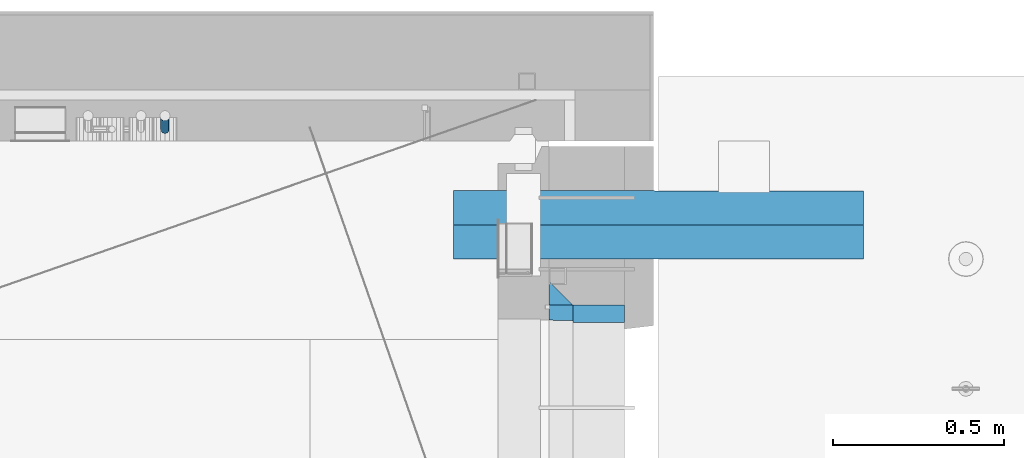
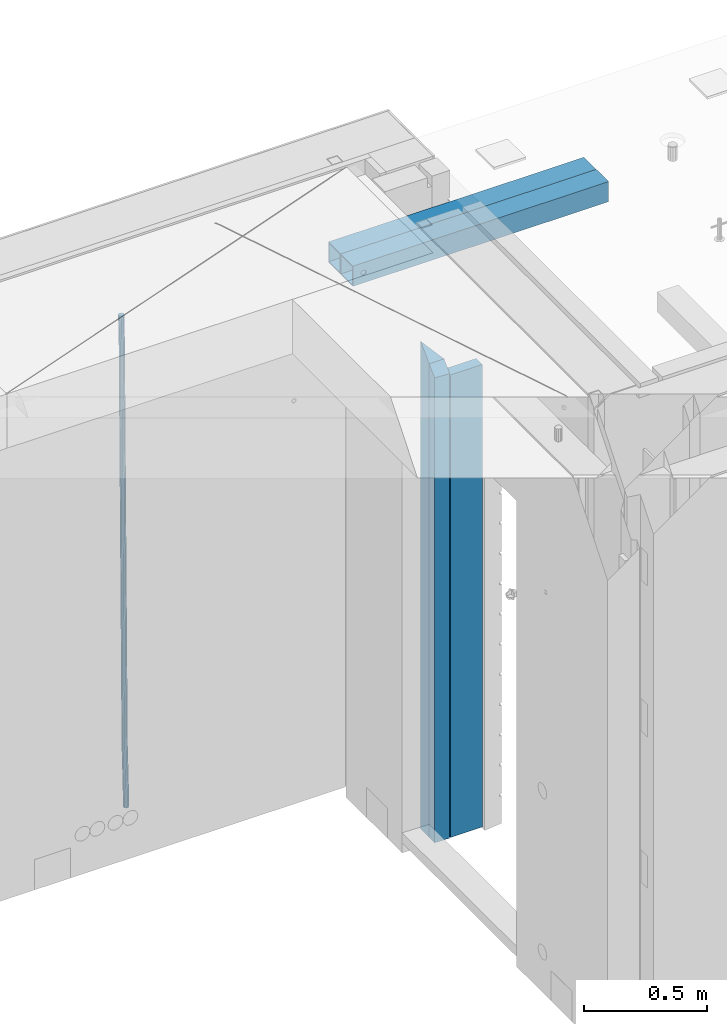
# One storey, part 110 of 309: 6 beams, 5 elements without a shape of their own.
"""IFC2X3 building model written with IfcOpenShell, lengths in millimetres."""

import ifcopenshell
import ifcopenshell.guid

model = None  # the IFC model being written
_history = None  # IfcOwnerHistory: only IFC2X3 demands one
_inside = {}  # id of a spatial element -> (the spatial element, [elements in it])
_under = {}  # id of a project, library or spatial element -> (it, [spatial elements below it])
_declared = {}  # id of a project -> (the project, [libraries it declares])
_typed = {}  # id of a type object -> (the type object, [elements of that type])
_made_of = {}  # id of a material, layer set ... -> (it, [elements and type objects made of it])


def new_model(schema):
    """Start an empty IFC model of exactly this schema.

    Asked for "IFC4X3", IfcOpenShell would pick the latest addendum, in which some entities
    have other attributes; the version numbers below select the first issue.
    IFC2X3 requires an IfcOwnerHistory on every rooted entity: one is made here for all.
    """
    global model, _history
    if schema == "IFC4X3":
        model = ifcopenshell.file(schema_version=(4, 3, 0, 0))
    else:
        model = ifcopenshell.file(schema=schema)
    _inside.clear()
    _under.clear()
    _declared.clear()
    _typed.clear()
    _made_of.clear()
    _history = None
    if model.schema == "IFC2X3":
        org = make("IfcOrganization", Name="unknown")
        user = make(
            "IfcPersonAndOrganization",
            ThePerson=make("IfcPerson", FamilyName="unknown"),
            TheOrganization=org,
        )
        app = make(
            "IfcApplication",
            ApplicationDeveloper=org,
            Version="unknown",
            ApplicationFullName="unknown",
            ApplicationIdentifier="unknown",
        )
        _history = make(
            "IfcOwnerHistory",
            OwningUser=user,
            OwningApplication=app,
            ChangeAction="ADDED",
            CreationDate=0,
        )
    return model


def make(cls, **values):
    """One entity of the class cls with the attributes given. An attribute that is None is left unset."""
    return model.create_entity(
        cls, **{name: value for name, value in values.items() if value is not None}
    )


def rooted(cls, **values):
    """An entity with a GlobalId (a new one), such as an element, a storey or a relation."""
    return make(cls, GlobalId=ifcopenshell.guid.new(), OwnerHistory=_history, **values)


def si_unit(unit_type, name, prefix=None):
    """IfcSIUnit, for example si_unit("LENGTHUNIT", "METRE", prefix="MILLI")."""
    return make("IfcSIUnit", UnitType=unit_type, Prefix=prefix, Name=name)


def assignment(units):
    """IfcUnitAssignment: the units of a project."""
    return None if units is None else make("IfcUnitAssignment", Units=units)


def point(xyz):
    """IfcCartesianPoint."""
    return None if xyz is None else make("IfcCartesianPoint", Coordinates=xyz)


def direction(xyz):
    """IfcDirection."""
    return None if xyz is None else make("IfcDirection", DirectionRatios=xyz)


def frame(location, z_axis=None, x_axis=None):
    """IfcAxis2Placement3D, a coordinate frame: its origin and axes. An axis left out is left unset."""
    return make(
        "IfcAxis2Placement3D",
        Location=point(location),
        Axis=direction(z_axis),
        RefDirection=direction(x_axis),
    )


def origin_with_axes():
    """The frame at (0, 0, 0) with the z axis (0, 0, 1) and the x axis (1, 0, 0) written out."""
    return frame((0.0, 0.0, 0.0), z_axis=(0.0, 0.0, 1.0), x_axis=(1.0, 0.0, 0.0))


def place(relative_to, where):
    """IfcLocalPlacement: puts the frame where relative to a parent placement (None: the world)."""
    return make(
        "IfcLocalPlacement", PlacementRelTo=relative_to, RelativePlacement=where
    )


def context(
    kind, dimensions, precision=None, world=None, true_north=None, identifier=None
):
    """IfcGeometricRepresentationContext, for example the 3D "Model" context."""
    return make(
        "IfcGeometricRepresentationContext",
        ContextIdentifier=identifier,
        ContextType=kind,
        CoordinateSpaceDimension=dimensions,
        Precision=precision,
        WorldCoordinateSystem=world,
        TrueNorth=true_north,
    )


def subcontext(parent, identifier, kind, view, scale=None):
    """IfcGeometricRepresentationSubContext, for example "Body" below "Model"."""
    return make(
        "IfcGeometricRepresentationSubContext",
        ContextIdentifier=identifier,
        ContextType=kind,
        ParentContext=parent,
        TargetScale=scale,
        TargetView=view,
    )


def project(units=None, contexts=None):
    """IfcProject with its units and contexts."""
    return rooted(
        "IfcProject",
        Name="project",
        RepresentationContexts=contexts,
        UnitsInContext=assignment(units),
    )


def spatial(cls, under=None, at=None, **own):
    """A site, building, storey or space (cls), placed at a placement, below another one or the project."""
    s = rooted(cls, ObjectPlacement=at, **own)
    if under is not None:
        _under.setdefault(under.id(), (under, []))[1].append(s)
    return s


def faces_of(points, faces, orient=None, outer=None):
    """IfcFace entities. A face is a list of loops; a loop is a list of indices into points, from 0.

    orient and outer hold one flag for each loop. By default every Orientation is true, the
    first loop of a face is its IfcFaceOuterBound and the others are IfcFaceBound.
    """
    made = []
    for i, loops in enumerate(faces):
        bounds = []
        for j, loop in enumerate(loops):
            is_outer = j == 0 if outer is None else outer[i][j]
            bounds.append(
                make(
                    "IfcFaceOuterBound" if is_outer else "IfcFaceBound",
                    Bound=make("IfcPolyLoop", Polygon=[points[k] for k in loop]),
                    Orientation=True if orient is None else orient[i][j],
                )
            )
        made.append(make("IfcFace", Bounds=bounds))
    return made


def faceted_brep(points, faces, orient=None, outer=None, voids=None):
    """IfcFacetedBrep: a solid bounded by flat faces; with voids (closed shells), ...WithVoids."""
    shared = [point(p) for p in points]
    hull = make("IfcClosedShell", CfsFaces=faces_of(shared, faces, orient, outer))
    if voids is None:
        return make("IfcFacetedBrep", Outer=hull)
    return make(
        "IfcFacetedBrepWithVoids",
        Outer=hull,
        Voids=[
            make(cls, CfsFaces=faces_of(shared, fs, o, b)) for cls, fs, o, b in voids
        ],
    )


def shape(context_of_items, identifier, shape_type, items):
    """IfcShapeRepresentation: the items that make up one representation, for example the "Body"."""
    return make(
        "IfcShapeRepresentation",
        ContextOfItems=context_of_items,
        RepresentationIdentifier=identifier,
        RepresentationType=shape_type,
        Items=items,
    )


def material(Name=None, Category=None):
    """IfcMaterial."""
    return make("IfcMaterial", Name=Name, Category=Category)


def made_of(thing, what):
    """Note that an element or type object is made of a material, layer set ...; save() writes the relation."""
    if what is not None:
        _made_of.setdefault(what.id(), (what, []))[1].append(thing)
    return thing


def type_object(cls, material=None, **own):
    """A type object (cls), such as IfcWallType, which elements share."""
    return made_of(rooted(cls, **own), material)


def element(
    cls,
    number,
    at=None,
    inside=None,
    cuts=None,
    type_object=None,
    material=None,
    context=None,
    identifier="Body",
    shape_type=None,
    held_by="IfcProductDefinitionShape",
    body=None,
    shapes=None,
    **own,
):
    """One element of the class cls, such as IfcWall. Its Tag is "e" and its number.

    at: its placement. inside: the storey or other place that contains it. cuts: it is an
    opening in that element (IfcRelVoidsElement). A single representation is given by context,
    identifier, shape_type and body (its items); several are given by shapes. held_by: the class
    of the entity that holds the representations. save() writes the other relations.
    """
    e = rooted(cls, Tag="e%d" % number, ObjectPlacement=at, **own)
    if body is not None:
        shapes = [shape(context, identifier, shape_type, body)]
    if shapes is not None:
        e.Representation = make(held_by, Representations=shapes)
    if inside is not None:
        _inside.setdefault(inside.id(), (inside, []))[1].append(e)
    if cuts is not None:
        rooted(
            "IfcRelVoidsElement", RelatingBuildingElement=cuts, RelatedOpeningElement=e
        )
    if type_object is not None:
        _typed.setdefault(type_object.id(), (type_object, []))[1].append(e)
    return made_of(e, material)


def aggregate(whole, parts):
    """IfcRelAggregates: a whole, such as a stair, and the parts it consists of."""
    return rooted("IfcRelAggregates", RelatingObject=whole, RelatedObjects=parts)


def save(model, path):
    """Write the relations noted so far, then the file.

    IfcRelAggregates (storeys below a building ...), IfcRelContainedInSpatialStructure (elements
    in a storey), IfcRelDefinesByType, IfcRelAssociatesMaterial and IfcRelDeclares: one each for
    every whole, place, type object, material and project.
    """
    for whole, parts in _under.values():
        aggregate(whole, parts)
    for where, things in _inside.values():
        rooted(
            "IfcRelContainedInSpatialStructure",
            RelatedElements=things,
            RelatingStructure=where,
        )
    for kind, things in _typed.values():
        rooted("IfcRelDefinesByType", RelatedObjects=things, RelatingType=kind)
    for what, things in _made_of.values():
        rooted("IfcRelAssociatesMaterial", RelatedObjects=things, RelatingMaterial=what)
    for by, libraries in _declared.values():
        rooted("IfcRelDeclares", RelatingContext=by, RelatedDefinitions=libraries)
    model.write(path)


model = new_model("IFC2X3")

# Units and contexts
model_context = context("Model", 3, precision=1e-05, world=origin_with_axes())
body_context = subcontext(model_context, "Body", "Model", "MODEL_VIEW")
ifc_project = project(units=[si_unit("LENGTHUNIT", "METRE", prefix="MILLI"), si_unit("AREAUNIT", "SQUARE_METRE"), si_unit("VOLUMEUNIT", "CUBIC_METRE"), si_unit("MASSUNIT", "GRAM", prefix="KILO"), si_unit("TIMEUNIT", "SECOND"), si_unit("PLANEANGLEUNIT", "RADIAN"), si_unit("SOLIDANGLEUNIT", "STERADIAN"), si_unit("THERMODYNAMICTEMPERATUREUNIT", "DEGREE_CELSIUS"), si_unit("LUMINOUSINTENSITYUNIT", "LUMEN")], contexts=[model_context])

# Site, building, storey
site_placement = place(None, origin_with_axes())
site = spatial("IfcSite", under=ifc_project, at=site_placement, CompositionType="ELEMENT")
building_placement = place(site_placement, origin_with_axes())
building = spatial("IfcBuilding", under=site, at=building_placement, CompositionType="ELEMENT")
storey_placement = place(building_placement, origin_with_axes())
storey = spatial("IfcBuildingStorey", under=building, at=storey_placement, Name="7", CompositionType="ELEMENT", Elevation=0.0)

# Assembly, beams
assembly_1_placement = place(storey_placement, origin_with_axes())
assembly_1 = element("IfcElementAssembly", 1, at=assembly_1_placement, inside=storey, AssemblyPlace="NOTDEFINED", PredefinedType="REINFORCEMENT_UNIT")
ifc_material_1 = material(Name="CONCRETE/C25/30")
beam_type_1 = type_object("IfcBeamType", PredefinedType="NOTDEFINED")
beam_1_placement = place(assembly_1_placement, frame((31494.9951872276, 22174.9998901814, 102175.0), z_axis=(0.0, -1.0, 0.0), x_axis=(0.0, 0.0, -1.0)))
beam_1 = element("IfcBeam", 2, at=beam_1_placement, type_object=beam_type_1, material=ifc_material_1, Name="SK", context=body_context, shape_type="Brep", body=[
    faceted_brep([(2420.0, -35.0, 35.0), (2420.0, -35.0, -35.0), (2420.0, 35.0, 35.0), (70.0000000000164, 35.0, 35.0), (70.0000000000164, -35.0, 35.0), (0.0, -35.0, -35.0)], [[[0, 1, 2]], [[0, 2, 3, 4]], [[1, 0, 4, 5]], [[2, 1, 5, 3]], [[4, 3, 5]]]),
])
beam_type_2 = type_object("IfcBeamType", PredefinedType="NOTDEFINED")
beam_2_placement = place(assembly_1_placement, frame((31494.9951872276, 22114.9998901814, 102105.0), z_axis=(0.0, -1.0, 0.0), x_axis=(0.0, 0.0, -1.0)))
beam_2 = element("IfcBeam", 3, at=beam_2_placement, type_object=beam_type_2, material=ifc_material_1, Name="SK", context=body_context, shape_type="Brep", body=[
    faceted_brep([(2350.0, -35.0, -25.0), (2350.0, 35.0, -25.0), (2350.0, 35.0, 20.6410256410309), (2350.0, -35.0, 18.8461538461561), (0.0, 35.0, -25.0), (45.6410256410309, 35.0, 20.6410256410254), (43.8461538461561, -35.0, 18.8461538461543), (0.0, -35.0, -25.0)], [[[0, 1, 2, 3]], [[2, 1, 4, 5]], [[3, 2, 5, 6]], [[0, 3, 6, 7]], [[1, 0, 7, 4]], [[5, 4, 7, 6]]]),
])
ifc_material_2 = material(Name="TIMBER")
beam_type_3 = type_object("IfcBeamType", Name="50X150", PredefinedType="NOTDEFINED")
beam_3_placement = place(assembly_1_placement, frame((31604.9951872276, 22114.9998901814, 102055.0), z_axis=(0.0, -1.0, 0.0), x_axis=(0.0, 0.0, -1.0)))
beam_3 = element("IfcBeam", 4, at=beam_3_placement, type_object=beam_type_3, material=ifc_material_2, ObjectType="50X150", context=body_context, shape_type="Brep", body=[
    faceted_brep([(0.0, 75.0, -25.0), (1.81898940354586e-12, 75.0, 25.0), (2295.00000000001, 75.0, 25.0), (2295.0, 75.0, -25.0), (1.81898940354586e-12, -75.0000000000009, 25.0), (2295.00000000001, -75.0, 25.0), (0.0, -75.0, -25.0), (2295.0, -75.0, -25.0)], [[[0, 1, 2, 3]], [[1, 4, 5, 2]], [[4, 6, 7, 5]], [[6, 0, 3, 7]], [[5, 7, 3, 2]], [[6, 4, 1, 0]]]),
])
aggregate(assembly_1, [beam_1, beam_2, beam_3])

# Assembly, beam
assembly_2_placement = place(storey_placement, origin_with_axes())
assembly_2 = element("IfcElementAssembly", 5, at=assembly_2_placement, inside=storey, AssemblyPlace="NOTDEFINED", PredefinedType="REINFORCEMENT_UNIT")
ifc_material_3 = material()
beam_type_4 = type_object("IfcBeamType", Name="D25", PredefinedType="NOTDEFINED")
beam_4_placement = place(assembly_2_placement, frame((30335.0000000039, 22654.9999977209, 99990.0), z_axis=(-0.000205762999925498, 0.999642804629538, -0.0267249099901004), x_axis=(4.30000201928125e-08, 0.0267249099948059, 0.999642825806181)))
beam_4 = element("IfcBeam", 6, at=beam_4_placement, type_object=beam_type_4, material=ifc_material_3, Name="JM25", ObjectType="D25", context=body_context, shape_type="Brep", body=[
    faceted_brep([(-7.41420080885291e-08, -12.5, -3.63797880709171e-12), (-6.42030499875546e-08, -10.8253175473074, -6.25000000000364), (60.4103898235917, -10.8253175318459, -6.2499999938409), (60.4103898269532, -12.4999999845422, 6.16273609921336e-09), (-3.70782800018787e-08, -6.25000000000364, -10.8253175473074), (60.4103898202884, -6.24999998454587, -10.8253175411446), (-1.45519152283669e-11, -3.63797880709171e-12, -12.5), (60.4103898179019, 1.54577719513327e-08, -12.4999999938373), (3.70637280866504e-08, 6.25, -10.8253175473074), (60.410389817087, 6.25000001545777, -10.825317541141), (6.42030499875546e-08, 10.8253175473001, -6.25000000000364), (60.410389818062, 10.8253175627578, -6.24999999383726), (7.41420080885291e-08, 12.4999999999927, 0.0), (60.4103898205503, 12.5000000154541, 6.16273609921336e-09), (6.42176019027829e-08, 10.8253175473001, 6.24999999999636), (60.4103898238973, 10.8253175627651, 6.2500000061591), (3.70928319171071e-08, 6.24999999999636, 10.8253175473037), (60.4103898272151, 6.25000001546141, 10.8253175534664), (1.45519152283669e-11, -3.63797880709171e-12, 12.4999999999964), (60.4103898296162, 1.54541339725256e-08, 12.5000000061591), (-3.7049176171422e-08, -6.25000000000364, 10.8253175473001), (60.4103898304165, -6.24999998454587, 10.8253175534701), (-6.41884980723262e-08, -10.8253175473074, 6.25), (60.4103898294561, -10.8253175318459, 6.25000000616637), (61.0324985728803, -10.8253175316895, -6.24999999377542), (60.991802792938, -12.4999999843931, 6.22458173893392e-09), (61.0622854283865, -6.24999998437852, -10.8253175410755), (61.0731819955545, 1.5628756955266e-08, -12.4999999937718), (61.0622685480339, 6.25000001562512, -10.8253175410791), (61.032469335245, 10.8253175629216, -6.24999999377178), (60.9917690322181, 12.5000000156033, 6.22458173893392e-09), (60.9510732522613, 10.8253175629034, 6.25000000621731), (60.9212863967696, 6.25000001558874, 10.8253175535247), (60.9103898296162, 1.55814632307738e-08, 12.5000000062137), (60.9213032771368, -6.24999998441126, 10.8253175535174), (60.9511024898966, -10.8253175317113, 6.25000000621731), (61.6545545670233, -10.8253158516927, -6.24189838219536), (61.573166454793, -12.499998414296, 0.00757164385504439), (61.7141257553885, -6.24999822394238, -10.8168280205282), (61.7359179680789, 1.80548886419274e-06, -12.491368569139), (61.7140919992817, 6.25000177601396, -10.8168282403167), (61.6544960997562, 10.8253192428383, -6.2418987628771), (61.5730989426083, 12.5000015856094, 0.0075712042817031), (61.4917108303925, 10.8253190230062, 6.25704123032847), (61.4321396420273, 6.25000139525582, 10.8319708686649), (61.4103474293224, 1.36582457344048e-06, 12.5065114172721), (61.4321733981196, -6.24999860470052, 10.8319710884571), (61.4917692976451, -10.8253160715249, 6.25704161101385), (176.524302641745, -10.8250056210964, -4.74584321979273), (176.442914529529, -12.4996881836996, 1.50362680625403), (176.583873830095, -6.24968799334965, -9.3207728581292), (176.605666042786, 0.000312036081595579, -10.9953134067364), (176.583840074018, 6.25031200660669, -9.32077307791769), (176.524244174492, 10.8256294734347, -4.74584360047811), (176.44284701733, 12.5003118162058, 1.50362636668069), (176.361458905099, 10.8256292535989, 7.75309639272746), (176.301887716749, 6.25031162585219, 12.3280260310676), (176.280095504058, 0.000311596420942806, 14.0025665796711), (176.301921472827, -6.24968837410415, 12.3280262508561), (176.361517372367, -10.8250058409321, 7.75309677341284), (177.085397012124, -10.8250041057399, -4.73853556792164), (176.983633547483, -12.4996867233749, 1.51066909103247), (177.159881729676, -6.24968643771717, -9.31327097355097), (177.187129580227, 0.000313606451527448, -10.987740468332), (177.159839524218, 6.25031356221734, -9.31327130338468), (177.085323910098, 10.8256309887511, -4.73853613920801), (176.983549136537, 12.5003132764905, 1.51066843136869), (176.881785671867, 10.8256306588555, 7.7598730903228), (176.80730095433, 6.25031299082912, 12.3346084959521), (176.780053103794, 0.000312946667690994, 14.0090779907332), (176.807343159802, -6.2496870091054, 12.3346088257895), (176.881858773908, -10.8250044356355, 7.7598736616128), (177.646431799818, -10.8250018318176, -4.72756919822132), (177.524295146417, -12.4996845320202, 1.52123723245313), (177.735828462886, -6.24968410334986, -9.30201312475765), (177.768531371941, 0.00031596292683389, -10.9763759912421), (177.735777808921, 6.25031589654827, -9.30201361973741), (177.646344064575, 10.8256332626152, -4.72757005553649), (177.524193838486, 12.5003154677688, 1.52123624250817), (177.402057185071, 10.8256327675663, 7.77004267317898), (177.312660521988, 6.2503150390985, 12.3444865997226), (177.279957612933, 0.00031497282179771, 14.0188494661961), (177.312711175953, -6.24968496079964, 12.3444870946951), (177.402144920314, -10.8250023268702, 7.77004353049415), (299.377443161706, -10.8245084454466, -2.34813158632096), (299.255306508276, -12.4991911456491, 3.90067484435349), (299.466839824803, -6.24919071697514, -6.92257551286093), (299.499542733873, 0.0008093492979242, -8.59693837933446), (299.466789170867, 6.250809282923, -6.92257600783341), (299.377355426492, 10.8261266489935, -2.34813244364341), (299.255205200388, 12.5008088541435, 3.90067385440125), (299.133068546944, 10.826126153941, 10.1494802850757), (299.043671883861, 6.25080842546959, 14.7239242116229), (299.010968974762, 0.000808359200163977, 16.3982870780892), (299.043722537797, -6.24919157442127, 14.7239247065918), (299.133156282158, -10.8245089404954, 10.1494811423981), (299.98561436501, -10.8245059804758, -2.33624385599614), (299.97179243555, -12.4991882411778, 3.91467976726199), (299.995742293278, -6.24918857328521, -6.91223722345239), (299.999447243041, 0.000811375455668895, -8.58716690387519), (299.995736475976, 6.25081142679483, -6.91223684201032), (299.985604289133, 10.8261291142808, -2.33624319533556), (299.971750386685, 12.5008117588586, 3.91467993563856), (299.957928457196, 10.8261294971744, 10.1656035610831), (299.947800528913, 6.25081208998381, 14.7415969285394), (299.944095579151, 0.00081214124293183, 16.4165266089549), (299.947806346216, -6.24918791008895, 14.7415965471009), (299.957938533058, -10.8245055975785, 10.1656029004225), (300.593832239858, -10.8245078794353, -2.34543881707941), (300.688302931099, -12.4991904788549, 3.90384712594823), (300.524685350189, -6.24919022474205, -6.92023371784308), (300.499390115292, 0.000809814544481924, -8.59472497713432), (300.524724372954, 6.25080977519247, -6.92023401429469), (300.593899829313, 10.8261272150703, -2.34543933054374), (300.688380976673, 12.5008095210287, 3.90384653304136), (300.782851667915, 10.8261269216127, 10.1531324760799), (300.851998557599, 6.25080926691589, 14.7279273768363), (300.877293792495, 0.000809227632998955, 16.4024186361276), (300.851959534804, -6.24919073302226, 14.7279276732806), (300.782784078474, -10.8245081728965, 10.153132989537), (2293.32930409742, -10.8307295605009, -32.4713622331001), (2293.42377478865, -12.5054121599169, -26.2220762900724), (2293.26015720774, -6.2554119058077, -37.0461571338565), (2293.23486197284, -0.00541186651753378, -38.7206483931477), (2293.26019623051, 6.24458809413409, -37.0461574303008), (2293.32937168686, 10.8199055340046, -32.4713627465644), (2293.42385283421, 12.4945878399631, -26.2220768829684), (2293.51832352545, 10.8199052405434, -19.972790939948), (2293.58747041514, 6.24458758585388, -15.3979960391844), (2293.61276565003, -0.00541245343265473, -13.7235047798931), (2293.58743139236, -6.25541241408428, -15.3979957427327), (2293.51825593603, -10.8307298539585, -19.9727904264691), (2294.0420846676, -10.8307317859326, -32.4821379598216), (2294.03681932652, -12.5054140739521, -26.2313442200393), (2294.06778164886, -6.2554144273563, -37.0583666982457), (2294.10702478497, -0.00541458957013674, -38.7338336404937), (2294.14929890928, 6.24458531819619, -37.0595987724118), (2294.18327670435, 10.8199028679592, -32.4842719748667), (2294.1998538474, 12.4945854171456, -26.2338083683717), (2294.19458850632, 10.819903129126, -19.9830146285858), (2294.16889152506, 6.24458577054975, -15.4067858901581), (2294.12964838895, -0.0054140672327776, -13.7313189479173), (2294.08737426462, -6.2554139749991, -15.4055538159919), (2294.05339646956, -10.8307315247621, -19.9808806135297), (2294.75482297382, -10.84002603931, -32.4726521173216), (2294.64982751427, -12.513407826169, -26.2231856868602), (2294.87535820232, -6.26594539088183, -37.0476186524102), (2294.97913588268, -0.0167870967634371, -38.7222267036377), (2295.0383488692, 6.23299192477134, -37.0477663960555), (2295.03713108998, 10.8087684320271, -32.4729080168181), (2294.97580884799, 12.4844668051373, -26.2234811741473), (2294.87081338844, 10.8110850182784, -19.9740147436787), (2294.7502781599, 6.23700436985018, -15.3990482086047), (2294.64650047956, -0.0121539242718427, -13.7244401573698), (2294.58728749304, -6.26193294580662, -15.3989004649666), (2294.58850527227, -10.8377094530588, -19.9737588441894), (2316.44667268227, -11.1228921988077, -32.1839550346631), (2316.34167722271, -12.7962739856739, -25.9344886042054), (2316.56720791078, -6.54881155039038, -36.7589215697517), (2316.67098559113, -0.299653256264719, -38.4335296209792), (2316.73019857766, 5.95012576527006, -36.759069313397), (2316.72898079845, 10.5259022725259, -32.1842109341669), (2316.66765855643, 12.2016006456361, -25.9347840914961), (2316.56266309689, 10.5282188587698, -19.6853176610275), (2316.44212786836, 5.95413821035254, -15.1103511259389), (2316.33835018802, -0.295020083769487, -13.4357430747186), (2316.27913720149, -6.54479910530426, -15.1102033823008), (2316.28035498071, -11.1205756125637, -19.685061761531), (2317.13234804722, -11.1318335458927, -32.1748293731798), (2317.04181141085, -12.8054038787741, -25.9251705100723), (2317.2154741603, -6.5572650749491, -36.7502937866229), (2317.26891617525, -0.307450393454928, -38.4255717558117), (2317.27835434731, 5.94297770185585, -36.7517739018112), (2317.24125972588, 10.5192220504723, -32.1773930078925), (2317.16757178486, 12.1950816748285, -25.9281307404563), (2317.0770351485, 10.5215113419545, -19.6784718773561), (2316.99390903539, 5.94694287101083, -15.1030074639057), (2316.94046702047, -0.302871810494253, -13.4277294947169), (2316.9310288484, -6.55329990579412, -15.1015273487101), (2316.96812346982, -11.1295442544142, -19.6759082426288), (2317.81808136747, -11.1298054502913, -32.1659056455355), (2317.74200467508, -12.803315894289, -25.9160547315114), (2317.86379538118, -6.55536082026447, -36.7418676070083), (2317.8668976831, -0.305700748642266, -38.417815303761), (2317.82655701396, 5.94458339541234, -36.7446799039099), (2317.75358262347, 10.5207330230332, -32.1707766866384), (2317.66752794063, 12.1965725370646, -25.9216793252963), (2317.59145124823, 10.5230620930706, -19.6718284112721), (2317.54573723453, 5.94861746304377, -15.0958664497994), (2317.54263493262, -0.301042608574789, -13.4199187530394), (2317.58297560175, -6.55132675263303, -15.0930541529051), (2317.65594999224, -11.1274763802539, -19.6669573701693), (2417.81884292323, -10.831603083323, -30.8687911350135), (2417.74276623082, -12.505113527317, -24.618940220982), (2417.86455693691, -6.25715845329614, -35.4447530964935), (2417.86765923884, -0.00749838167394046, -37.1207007932499), (2417.82731856969, 6.24278576237703, -35.4475653933878), (2417.75434417921, 10.8189353900088, -30.8736621761236), (2417.66828949639, 12.494774904033, -24.6245648147851), (2417.59221280397, 10.8212644600353, -18.3747139007501), (2417.54649879028, 6.2468198300121, -13.79875193927), (2417.54339648837, -0.00284024161010166, -12.1228042425173), (2417.5837371575, -6.25312438566107, -13.795939642383), (2417.65671154798, -10.8292740132893, -18.3698428596399)], [[[0, 1, 2, 3]], [[1, 4, 5, 2]], [[4, 6, 7, 5]], [[6, 8, 9, 7]], [[8, 10, 11, 9]], [[10, 12, 13, 11]], [[12, 14, 15, 13]], [[14, 16, 17, 15]], [[16, 18, 19, 17]], [[18, 20, 21, 19]], [[20, 22, 23, 21]], [[22, 0, 3, 23]], [[22, 20, 18, 16, 14, 12, 10, 8, 6, 4, 1, 0]], [[3, 2, 24, 25]], [[2, 5, 26, 24]], [[5, 7, 27, 26]], [[7, 9, 28, 27]], [[9, 11, 29, 28]], [[11, 13, 30, 29]], [[13, 15, 31, 30]], [[15, 17, 32, 31]], [[17, 19, 33, 32]], [[19, 21, 34, 33]], [[21, 23, 35, 34]], [[23, 3, 25, 35]], [[25, 24, 36, 37]], [[24, 26, 38, 36]], [[26, 27, 39, 38]], [[27, 28, 40, 39]], [[28, 29, 41, 40]], [[29, 30, 42, 41]], [[30, 31, 43, 42]], [[31, 32, 44, 43]], [[32, 33, 45, 44]], [[33, 34, 46, 45]], [[34, 35, 47, 46]], [[35, 25, 37, 47]], [[37, 36, 48, 49]], [[36, 38, 50, 48]], [[38, 39, 51, 50]], [[39, 40, 52, 51]], [[40, 41, 53, 52]], [[41, 42, 54, 53]], [[42, 43, 55, 54]], [[43, 44, 56, 55]], [[44, 45, 57, 56]], [[45, 46, 58, 57]], [[46, 47, 59, 58]], [[47, 37, 49, 59]], [[49, 48, 60, 61]], [[48, 50, 62, 60]], [[50, 51, 63, 62]], [[51, 52, 64, 63]], [[52, 53, 65, 64]], [[53, 54, 66, 65]], [[54, 55, 67, 66]], [[55, 56, 68, 67]], [[56, 57, 69, 68]], [[57, 58, 70, 69]], [[58, 59, 71, 70]], [[59, 49, 61, 71]], [[61, 60, 72, 73]], [[60, 62, 74, 72]], [[62, 63, 75, 74]], [[63, 64, 76, 75]], [[64, 65, 77, 76]], [[65, 66, 78, 77]], [[66, 67, 79, 78]], [[67, 68, 80, 79]], [[68, 69, 81, 80]], [[69, 70, 82, 81]], [[70, 71, 83, 82]], [[71, 61, 73, 83]], [[73, 72, 84, 85]], [[72, 74, 86, 84]], [[74, 75, 87, 86]], [[75, 76, 88, 87]], [[76, 77, 89, 88]], [[77, 78, 90, 89]], [[78, 79, 91, 90]], [[79, 80, 92, 91]], [[80, 81, 93, 92]], [[81, 82, 94, 93]], [[82, 83, 95, 94]], [[83, 73, 85, 95]], [[85, 84, 96, 97]], [[84, 86, 98, 96]], [[86, 87, 99, 98]], [[87, 88, 100, 99]], [[88, 89, 101, 100]], [[89, 90, 102, 101]], [[90, 91, 103, 102]], [[91, 92, 104, 103]], [[92, 93, 105, 104]], [[93, 94, 106, 105]], [[94, 95, 107, 106]], [[95, 85, 97, 107]], [[97, 96, 108, 109]], [[96, 98, 110, 108]], [[98, 99, 111, 110]], [[99, 100, 112, 111]], [[100, 101, 113, 112]], [[101, 102, 114, 113]], [[102, 103, 115, 114]], [[103, 104, 116, 115]], [[104, 105, 117, 116]], [[105, 106, 118, 117]], [[106, 107, 119, 118]], [[107, 97, 109, 119]], [[109, 108, 120, 121]], [[108, 110, 122, 120]], [[110, 111, 123, 122]], [[111, 112, 124, 123]], [[112, 113, 125, 124]], [[113, 114, 126, 125]], [[114, 115, 127, 126]], [[115, 116, 128, 127]], [[116, 117, 129, 128]], [[117, 118, 130, 129]], [[118, 119, 131, 130]], [[119, 109, 121, 131]], [[121, 120, 132, 133]], [[120, 122, 134, 132]], [[122, 123, 135, 134]], [[123, 124, 136, 135]], [[124, 125, 137, 136]], [[125, 126, 138, 137]], [[126, 127, 139, 138]], [[127, 128, 140, 139]], [[128, 129, 141, 140]], [[129, 130, 142, 141]], [[130, 131, 143, 142]], [[131, 121, 133, 143]], [[133, 132, 144, 145]], [[132, 134, 146, 144]], [[134, 135, 147, 146]], [[135, 136, 148, 147]], [[136, 137, 149, 148]], [[137, 138, 150, 149]], [[138, 139, 151, 150]], [[139, 140, 152, 151]], [[140, 141, 153, 152]], [[141, 142, 154, 153]], [[142, 143, 155, 154]], [[143, 133, 145, 155]], [[145, 144, 156, 157]], [[144, 146, 158, 156]], [[146, 147, 159, 158]], [[147, 148, 160, 159]], [[148, 149, 161, 160]], [[149, 150, 162, 161]], [[150, 151, 163, 162]], [[151, 152, 164, 163]], [[152, 153, 165, 164]], [[153, 154, 166, 165]], [[154, 155, 167, 166]], [[155, 145, 157, 167]], [[157, 156, 168, 169]], [[156, 158, 170, 168]], [[158, 159, 171, 170]], [[159, 160, 172, 171]], [[160, 161, 173, 172]], [[161, 162, 174, 173]], [[162, 163, 175, 174]], [[163, 164, 176, 175]], [[164, 165, 177, 176]], [[165, 166, 178, 177]], [[166, 167, 179, 178]], [[167, 157, 169, 179]], [[169, 168, 180, 181]], [[168, 170, 182, 180]], [[170, 171, 183, 182]], [[171, 172, 184, 183]], [[172, 173, 185, 184]], [[173, 174, 186, 185]], [[174, 175, 187, 186]], [[175, 176, 188, 187]], [[176, 177, 189, 188]], [[177, 178, 190, 189]], [[178, 179, 191, 190]], [[179, 169, 181, 191]], [[181, 180, 192, 193]], [[180, 182, 194, 192]], [[182, 183, 195, 194]], [[183, 184, 196, 195]], [[184, 185, 197, 196]], [[185, 186, 198, 197]], [[186, 187, 199, 198]], [[187, 188, 200, 199]], [[188, 189, 201, 200]], [[189, 190, 202, 201]], [[190, 191, 203, 202]], [[191, 181, 193, 203]], [[194, 195, 196, 197, 198, 199, 200, 201, 202, 203, 193, 192]]]),
])
aggregate(assembly_2, [beam_4])

# Assemblies, beams
assembly_3_placement = place(storey_placement, origin_with_axes())
assembly_3 = element("IfcElementAssembly", 7, at=assembly_3_placement, inside=storey, AssemblyPlace="NOTDEFINED", PredefinedType="REINFORCEMENT_UNIT")
assembly_4_placement = place(assembly_3_placement, origin_with_axes())
assembly_4 = element("IfcElementAssembly", 8, at=assembly_4_placement, AssemblyPlace="NOTDEFINED", PredefinedType="NOTDEFINED")
ifc_material_4 = material(Name="Undefined/350")
beam_type_5 = type_object("IfcBeamType", Name="100X100X5", PredefinedType="NOTDEFINED")
beam_5_placement = place(assembly_4_placement, frame((32380.0034426031, 22324.9998567989, 102555.0), z_axis=(0.0, 0.0, 1.0), x_axis=(-0.999999999752625, 2.22429999942101e-05, 0.0)))
beam_5 = element("IfcBeam", 9, at=beam_5_placement, type_object=beam_type_5, material=ifc_material_4, ObjectType="100X100X5", context=body_context, shape_type="Brep", body=[
    faceted_brep([(1139.17579440585, -49.9744051074349, 6.25), (1139.1757927444, -44.9999999999991, 6.25), (1143.75111029171, -44.9999999999991, 10.8253175473074), (1143.75111195316, -49.9744035792783, 10.8253175473074), (1150.00111029171, -44.9999999999991, 12.5), (1150.00111195316, -49.9744014917787, 12.5), (1156.25111029171, -44.9999999999991, 10.8253175473074), (1156.25111195316, -49.9743994042774, 10.8253175473074), (1160.82642783901, -44.9999999999991, 6.25), (1160.82642950046, -49.9743978761207, 6.25), (1162.50111029171, -44.9999999999991, 0.0), (1162.50111195316, -49.9743973167779, 0.0), (1160.82642783901, -44.9999999999991, -6.25), (1160.82642950046, -49.9743978761207, -6.25), (1156.25111029171, -44.9999999999991, -10.8253175473074), (1156.25111195316, -49.9743994042774, -10.8253175473074), (1150.00111029171, -44.9999999999991, -12.5), (1150.00111195316, -49.9744014917787, -12.5), (1143.75111029171, -44.9999999999991, -10.8253175473074), (1143.75111195316, -49.9744035792783, -10.8253175473074), (1139.1757927444, -44.9999999999991, -6.25), (1139.17579440585, -49.9744051074349, -6.25), (1137.50111029171, -44.9999999999991, 0.0), (1137.50111195316, -49.9744056667778, 0.0), (1139.1757626844, 44.9999999999982, 6.25), (1139.17576100585, 50.0255948914664, 6.25), (1143.75107855316, 50.0255964196231, 10.8253175473074), (1143.75108023171, 44.9999999999982, 10.8253175473074), (1150.00107855316, 50.0255985071226, 12.5), (1150.00108023171, 44.9999999999982, 12.5), (1156.25107855315, 50.0256005946221, 10.8253175473074), (1156.2510802317, 44.9999999999982, 10.8253175473074), (1160.82639610046, 50.0256021227788, 6.25), (1160.82639777901, 44.9999999999982, 6.25), (1162.50107855316, 50.0256026821226, 0.0), (1162.50108023171, 44.9999999999982, 0.0), (1160.82639610046, 50.0256021227788, -6.25), (1160.82639777901, 44.9999999999982, -6.25), (1156.25107855315, 50.0256005946221, -10.8253175473074), (1156.2510802317, 44.9999999999982, -10.8253175473074), (1150.00107855316, 50.0255985071226, -12.5), (1150.00108023171, 44.9999999999982, -12.5), (1143.75107855316, 50.0255964196231, -10.8253175473074), (1143.75108023171, 44.9999999999982, -10.8253175473074), (1139.17576100585, 50.0255948914664, -6.25), (1139.1757626844, 44.9999999999982, -6.25), (1137.50107855316, 50.0255943321226, 0.0), (1137.5010802317, 44.9999999999982, 0.0), (1.81898940354586e-12, -50.0000000000009, -50.0), (1.81898940354586e-12, 49.9999999999991, -50.0), (1200.00449189278, 49.9999999999982, -50.0), (1200.00449189278, -50.0000000000009, -50.0), (1.81898940354586e-12, -50.0000000000009, 50.0), (1200.00449189278, -50.0000000000009, 50.0), (1.81898940354586e-12, 49.9999999999991, 50.0), (1200.00449189278, 49.9999999999982, 50.0), (0.0, 44.9999999999991, 45.0), (1.81898940354586e-12, -45.0000000000009, 45.0), (1.81898940354586e-12, -45.0000000000009, -45.0), (0.0, 44.9999999999991, -45.0), (1200.00449189278, 44.9999999999982, -45.0), (1200.00449189278, 44.9999999999982, 45.0), (1200.00449189278, -45.0000000000009, 45.0), (1200.00449189278, -45.0000000000009, -45.0)], [[[0, 1, 2, 3]], [[3, 2, 4, 5]], [[5, 4, 6, 7]], [[7, 6, 8, 9]], [[9, 8, 10, 11]], [[11, 10, 12, 13]], [[13, 12, 14, 15]], [[15, 14, 16, 17]], [[17, 16, 18, 19]], [[19, 18, 20, 21]], [[21, 20, 22, 23]], [[23, 22, 1, 0]], [[24, 25, 26, 27]], [[27, 26, 28, 29]], [[29, 28, 30, 31]], [[31, 30, 32, 33]], [[33, 32, 34, 35]], [[35, 34, 36, 37]], [[37, 36, 38, 39]], [[39, 38, 40, 41]], [[41, 40, 42, 43]], [[43, 42, 44, 45]], [[45, 44, 46, 47]], [[47, 46, 25, 24]], [[48, 49, 50, 51]], [[52, 48, 51, 53], [15, 17, 19, 21, 23, 0, 3, 5, 7, 9, 11, 13]], [[54, 52, 53, 55]], [[48, 52, 54, 49], [56, 57, 58, 59]], [[56, 59, 60, 61], [39, 41, 43, 45, 47, 24, 27, 29, 31, 33, 35, 37]], [[57, 56, 61, 62]], [[58, 57, 62, 63], [6, 4, 2, 1, 22, 20, 18, 16, 14, 12, 10, 8]], [[59, 58, 63, 60]], [[53, 51, 50, 55], [62, 61, 60, 63]], [[49, 54, 55, 50], [30, 28, 26, 25, 46, 44, 42, 40, 38, 36, 34, 32]]]),
])
aggregate(assembly_4, [beam_5])
assembly_5_placement = place(assembly_3_placement, origin_with_axes())
assembly_5 = element("IfcElementAssembly", 10, at=assembly_5_placement, AssemblyPlace="NOTDEFINED", PredefinedType="NOTDEFINED")
aggregate(assembly_3, [assembly_4, assembly_5])
beam_6_placement = place(assembly_5_placement, frame((32380.0034426031, 22424.9998567989, 102555.0), z_axis=(0.0, 0.0, 1.0), x_axis=(-0.999999999752625, 2.22429999942101e-05, 0.0)))
beam_6 = element("IfcBeam", 11, at=beam_6_placement, type_object=beam_type_5, material=ifc_material_4, ObjectType="100X100X5", context=body_context, shape_type="Brep", body=[
    faceted_brep([(1139.17579440585, -49.9744051074349, 6.25), (1139.1757927444, -44.9999999999991, 6.25), (1143.75111029171, -44.9999999999991, 10.8253175473074), (1143.75111195316, -49.9744035792783, 10.8253175473074), (1150.00111029171, -44.9999999999991, 12.5), (1150.00111195316, -49.9744014917787, 12.5), (1156.25111029171, -44.9999999999991, 10.8253175473074), (1156.25111195316, -49.9743994042774, 10.8253175473074), (1160.82642783901, -44.9999999999991, 6.25), (1160.82642950046, -49.9743978761207, 6.25), (1162.50111029171, -44.9999999999991, 0.0), (1162.50111195316, -49.9743973167779, 0.0), (1160.82642783901, -44.9999999999991, -6.25), (1160.82642950046, -49.9743978761207, -6.25), (1156.25111029171, -44.9999999999991, -10.8253175473074), (1156.25111195316, -49.9743994042774, -10.8253175473074), (1150.00111029171, -44.9999999999991, -12.5), (1150.00111195316, -49.9744014917787, -12.5), (1143.75111029171, -44.9999999999991, -10.8253175473074), (1143.75111195316, -49.9744035792783, -10.8253175473074), (1139.1757927444, -44.9999999999991, -6.25), (1139.17579440585, -49.9744051074349, -6.25), (1137.50111029171, -44.9999999999991, 0.0), (1137.50111195316, -49.9744056667778, 0.0), (1139.1757626844, 44.9999999999982, 6.25), (1139.17576100585, 50.0255948914664, 6.25), (1143.75107855316, 50.0255964196231, 10.8253175473074), (1143.75108023171, 44.9999999999982, 10.8253175473074), (1150.00107855316, 50.0255985071226, 12.5), (1150.00108023171, 44.9999999999982, 12.5), (1156.25107855315, 50.0256005946221, 10.8253175473074), (1156.2510802317, 44.9999999999982, 10.8253175473074), (1160.82639610046, 50.0256021227788, 6.25), (1160.82639777901, 44.9999999999982, 6.25), (1162.50107855316, 50.0256026821226, 0.0), (1162.50108023171, 44.9999999999982, 0.0), (1160.82639610046, 50.0256021227788, -6.25), (1160.82639777901, 44.9999999999982, -6.25), (1156.25107855315, 50.0256005946221, -10.8253175473074), (1156.2510802317, 44.9999999999982, -10.8253175473074), (1150.00107855316, 50.0255985071226, -12.5), (1150.00108023171, 44.9999999999982, -12.5), (1143.75107855316, 50.0255964196231, -10.8253175473074), (1143.75108023171, 44.9999999999982, -10.8253175473074), (1139.17576100585, 50.0255948914664, -6.25), (1139.1757626844, 44.9999999999982, -6.25), (1137.50107855316, 50.0255943321226, 0.0), (1137.5010802317, 44.9999999999982, 0.0), (1.81898940354586e-12, -50.0000000000009, -50.0), (1.81898940354586e-12, 49.9999999999991, -50.0), (1200.00449189278, 49.9999999999982, -50.0), (1200.00449189278, -50.0000000000009, -50.0), (1.81898940354586e-12, -50.0000000000009, 50.0), (1200.00449189278, -50.0000000000009, 50.0), (1.81898940354586e-12, 49.9999999999991, 50.0), (1200.00449189278, 49.9999999999982, 50.0), (0.0, 44.9999999999991, 45.0), (1.81898940354586e-12, -45.0000000000009, 45.0), (1.81898940354586e-12, -45.0000000000009, -45.0), (0.0, 44.9999999999991, -45.0), (1200.00449189278, 44.9999999999982, -45.0), (1200.00449189278, 44.9999999999982, 45.0), (1200.00449189278, -45.0000000000009, 45.0), (1200.00449189278, -45.0000000000009, -45.0)], [[[0, 1, 2, 3]], [[3, 2, 4, 5]], [[5, 4, 6, 7]], [[7, 6, 8, 9]], [[9, 8, 10, 11]], [[11, 10, 12, 13]], [[13, 12, 14, 15]], [[15, 14, 16, 17]], [[17, 16, 18, 19]], [[19, 18, 20, 21]], [[21, 20, 22, 23]], [[23, 22, 1, 0]], [[24, 25, 26, 27]], [[27, 26, 28, 29]], [[29, 28, 30, 31]], [[31, 30, 32, 33]], [[33, 32, 34, 35]], [[35, 34, 36, 37]], [[37, 36, 38, 39]], [[39, 38, 40, 41]], [[41, 40, 42, 43]], [[43, 42, 44, 45]], [[45, 44, 46, 47]], [[47, 46, 25, 24]], [[48, 49, 50, 51]], [[52, 48, 51, 53], [15, 17, 19, 21, 23, 0, 3, 5, 7, 9, 11, 13]], [[54, 52, 53, 55]], [[48, 52, 54, 49], [56, 57, 58, 59]], [[56, 59, 60, 61], [39, 41, 43, 45, 47, 24, 27, 29, 31, 33, 35, 37]], [[57, 56, 61, 62]], [[58, 57, 62, 63], [6, 4, 2, 1, 22, 20, 18, 16, 14, 12, 10, 8]], [[59, 58, 63, 60]], [[53, 51, 50, 55], [62, 61, 60, 63]], [[49, 54, 55, 50], [30, 28, 26, 25, 46, 44, 42, 40, 38, 36, 34, 32]]]),
])
aggregate(assembly_5, [beam_6])

save(model, "model.ifc")
